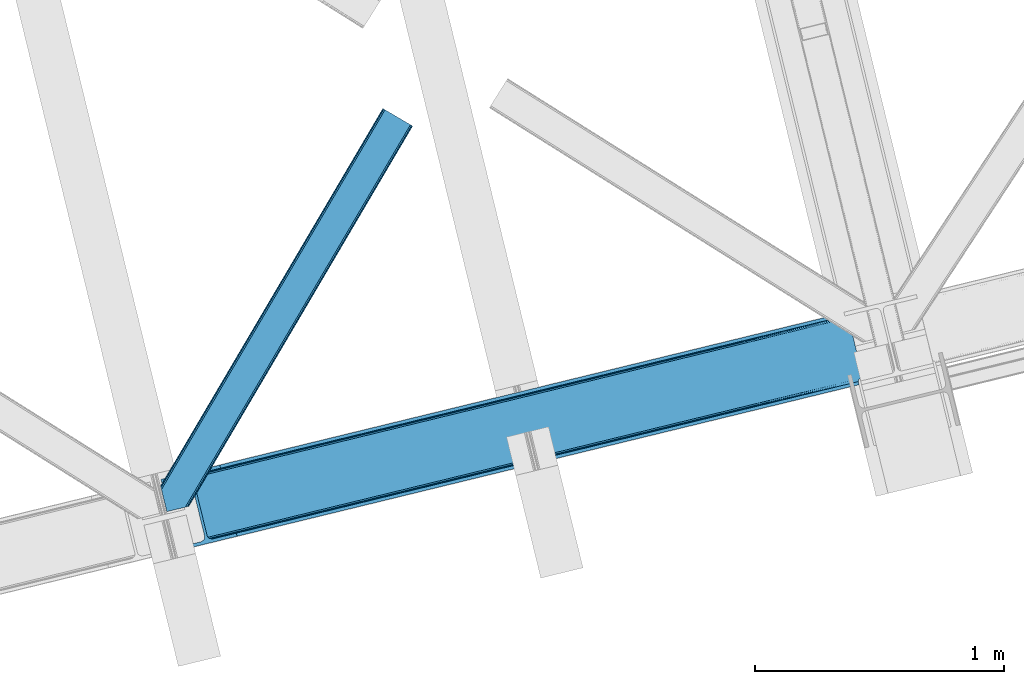
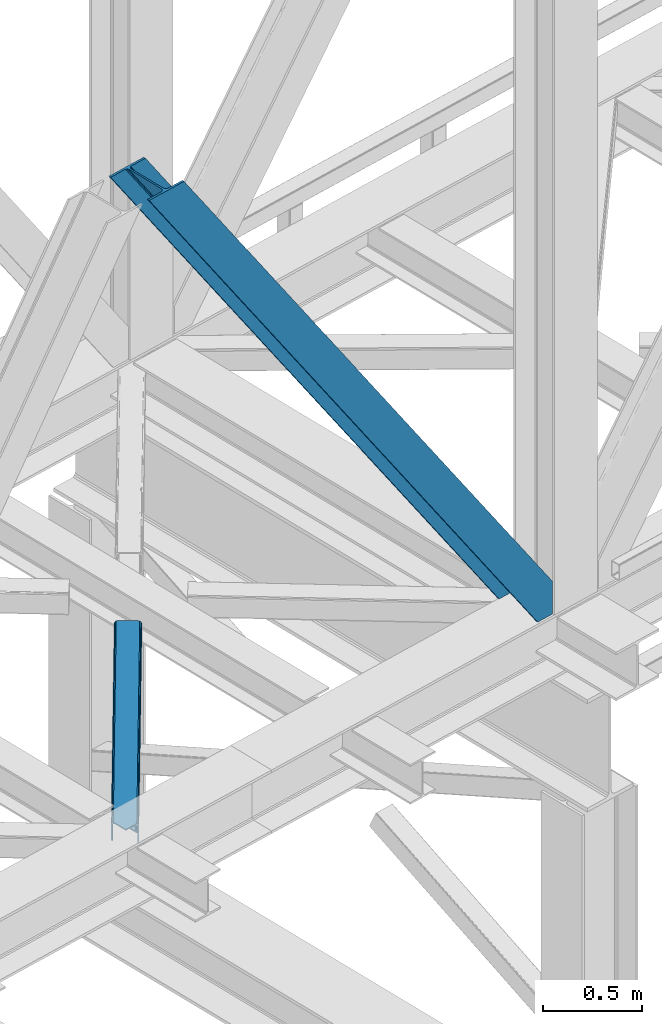
# One storey, part 34 of 93: 2 members.
"""IFC4 building model written with IfcOpenShell, lengths in millimetres."""

from ifc_helpers import new_model, entity, si_unit, converted_unit, derived_unit, direction, frame, origin, place, context, subcontext, project, spatial, triangles, type_object, element, save


model = new_model("IFC4")

# Units and contexts
model_context = context("Model", 3, precision=0.01, world=origin(), true_north=direction((6.12303176911189e-17, 1.0)))
plan_context = context("Plan", 3, precision=0.01, world=origin(), true_north=direction((6.12303176911189e-17, 1.0)))
body_context = subcontext(model_context, "Body", "Model", "MODEL_VIEW")
ifc_project = project(units=[si_unit("LENGTHUNIT", "METRE", prefix="MILLI"), si_unit("AREAUNIT", "SQUARE_METRE"), si_unit("VOLUMEUNIT", "CUBIC_METRE"), converted_unit("PLANEANGLEUNIT", "DEGREE", entity("IfcRatioMeasure", 0.0174532925199433), si_unit("PLANEANGLEUNIT", "RADIAN"), dimensions=[0, 0, 0, 0, 0, 0, 0]), si_unit("MASSUNIT", "GRAM", prefix="KILO"), derived_unit("MASSDENSITYUNIT", [(si_unit("MASSUNIT", "GRAM", prefix="KILO"), 1), (si_unit("LENGTHUNIT", "METRE"), -3)]), derived_unit("MOMENTOFINERTIAUNIT", [(si_unit("LENGTHUNIT", "METRE"), 4)]), si_unit("TIMEUNIT", "SECOND"), si_unit("FREQUENCYUNIT", "HERTZ"), si_unit("THERMODYNAMICTEMPERATUREUNIT", "DEGREE_CELSIUS"), derived_unit("THERMALTRANSMITTANCEUNIT", [(si_unit("MASSUNIT", "GRAM", prefix="KILO"), 1), (si_unit("THERMODYNAMICTEMPERATUREUNIT", "KELVIN"), -1), (si_unit("TIMEUNIT", "SECOND"), -3)]), derived_unit("VOLUMETRICFLOWRATEUNIT", [(si_unit("LENGTHUNIT", "METRE"), 3), (si_unit("TIMEUNIT", "SECOND"), -1)]), derived_unit("MASSFLOWRATEUNIT", [(si_unit("MASSUNIT", "GRAM", prefix="KILO"), 1), (si_unit("TIMEUNIT", "SECOND"), -1)]), derived_unit("ROTATIONALFREQUENCYUNIT", [(si_unit("TIMEUNIT", "SECOND"), -1)]), si_unit("ELECTRICCURRENTUNIT", "AMPERE"), si_unit("ELECTRICVOLTAGEUNIT", "VOLT"), si_unit("POWERUNIT", "WATT"), si_unit("FORCEUNIT", "NEWTON", prefix="KILO"), si_unit("ILLUMINANCEUNIT", "LUX"), si_unit("LUMINOUSFLUXUNIT", "LUMEN"), si_unit("LUMINOUSINTENSITYUNIT", "CANDELA"), derived_unit("USERDEFINED", [(si_unit("MASSUNIT", "GRAM", prefix="KILO"), -1), (si_unit("LENGTHUNIT", "METRE"), -2), (si_unit("TIMEUNIT", "SECOND"), 3), (si_unit("LUMINOUSFLUXUNIT", "LUMEN"), 1)]), derived_unit("LINEARVELOCITYUNIT", [(si_unit("LENGTHUNIT", "METRE"), 1), (si_unit("TIMEUNIT", "SECOND"), -1)]), si_unit("PRESSUREUNIT", "PASCAL"), derived_unit("USERDEFINED", [(si_unit("LENGTHUNIT", "METRE"), -2), (si_unit("MASSUNIT", "GRAM", prefix="KILO"), 1), (si_unit("TIMEUNIT", "SECOND"), -2)]), derived_unit("LINEARFORCEUNIT", [(si_unit("MASSUNIT", "GRAM", prefix="KILO"), 1), (si_unit("LENGTHUNIT", "METRE"), 1), (si_unit("TIMEUNIT", "SECOND"), -2), (si_unit("LENGTHUNIT", "METRE"), -1)]), derived_unit("PLANARFORCEUNIT", [(si_unit("MASSUNIT", "GRAM", prefix="KILO"), 1), (si_unit("LENGTHUNIT", "METRE"), 1), (si_unit("TIMEUNIT", "SECOND"), -2), (si_unit("LENGTHUNIT", "METRE"), -2)])], contexts=[model_context, plan_context])

# Site, building, storey
site_placement = place(None, origin())
site = spatial("IfcSite", under=ifc_project, at=site_placement, CompositionType="ELEMENT")
building_placement = place(site_placement, origin())
building = spatial("IfcBuilding", under=site, at=building_placement, CompositionType="ELEMENT")
storey_placement = place(building_placement, frame((0.0, 0.0, 15900.0)))
storey = spatial("IfcBuildingStorey", under=building, at=storey_placement, CompositionType="ELEMENT", Elevation=15900.0)

# Members
member_type_1 = type_object("IfcMemberType", PredefinedType="BRACE")
member_1_placement = place(storey_placement, frame((-51544.6723754883, 4902.22868041992, 3694.99929199219)))
element("IfcMember", 1, at=member_1_placement, inside=storey, type_object=member_type_1, ObjectType="Steel Vertical Brace", PredefinedType="BRACE", context=body_context, shape_type="Tessellation", body=[
    triangles([(2824.16715087891, 696.209248352051, 0.781347656247817), (2824.8368774414, 695.227331542968, 1.0697021484375), (2823.33929443359, 694.862237548828, 0.0), (2821.44173583984, 702.634437561035, 0.0), (2812.37717285156, 692.190307617188, 19.5569458007813), (2812.37717285156, 692.190307617188, 0.0), (2386.756640625, 583.573681640625, 658.75048828125), (2392.34234619141, 580.919773864746, 662.07819213867), (2803.98698730469, 681.261904907226, 51.2480346679658), (2804.11256103516, 683.186206054687, 44.4996093749978), (2382.25458984375, 588.487916564942, 656.525042724606), (2808.48438720703, 690.37995300293, 26.4030395507798), (2805.01483154297, 685.663961791992, 38.2720825195283), (2805.58223876953, 687.217936706543, 34.3676696777329), (630.515002441411, 150.045492553711, 3288.98063964843), (624.69210205078, 150.036772155761, 3285.05529785156), (211.331286621098, 47.8651016235353, 3911.00081176758), (202.862036132814, 47.2110717773439, 3911.00081176758), (619.106396484378, 152.691261291504, 3281.72759399414), (195.034606933594, 49.3185012817385, 3911.00081176758), (614.608996582036, 157.60549621582, 3279.50447387695), (189.034973144531, 53.8676422119142, 3911.00081176758), (611.88358154297, 164.031266784668, 3278.7231262207), (185.784008789065, 60.1649322509766, 3911.00081176758), (2804.10325927735, 679.880593872071, 63.6403015136711), (2398.16524658203, 580.928494262695, 666.003533935545), (1956.25268554688, 473.207743835449, 1321.74955444336), (1950.42978515625, 473.198442077637, 1317.82188720703), (1508.5172241211, 365.477691650391, 1973.56790771484), (1514.34012451172, 365.486993408203, 1977.49324951172), (1066.60466308594, 257.757522583008, 2629.3116027832), (1072.42756347657, 257.766242980957, 2633.23694458008), (1944.84407958984, 475.853512573242, 1314.49418334961), (1502.93151855469, 368.132180786133, 1970.23787841797), (1061.01895751953, 260.411430358887, 2625.98389892578), (1940.3466796875, 480.767166137695, 1312.27106323242), (1498.43411865235, 373.046997070313, 1968.01475830078), (1056.52155761719, 265.326246643066, 2623.75845336914), (2379.52917480469, 594.913687133789, 655.74602050781), (1937.62126464844, 487.192936706543, 1311.48971557617), (1495.70870361328, 379.47276763916, 1967.23341064453), (1053.79614257813, 271.751435852051, 2622.97710571289), (2766.2637084961, 929.006085205078, 0.0), (2324.35114746094, 821.285334777832, 655.74602050781), (1882.43858642579, 713.564584350586, 1311.48971557617), (1440.52602539062, 605.844415283203, 1967.23341064453), (998.613464355469, 498.123083496093, 2622.97710571289), (556.705554199223, 390.402914428711, 3278.7231262207), (130.605981445311, 286.53657989502, 3911.00081176758), (303.26520996094, 70.2741989135739, 3911.00081176758), (2804.10325927735, 679.880593872071, 200.055230712889), (2807.13563232422, 667.239505004883, 200.120343017577), (2804.2939453125, 678.898095703125, 200.120343017577), (306.344091796876, 57.6441558837887, 3911.00081176758), (2807.13563232422, 667.239505004883, 0.0), (2804.2939453125, 678.898095703125, 0.0), (2803.9962890625, 682.092668151856, 0.0), (2804.11256103516, 683.186206054687, 2.42078247070094), (2804.71717529297, 685.456416320801, 5.12991943359157), (2805.58223876953, 687.217936706543, 5.67639770507594), (2807.01470947266, 689.087008666992, 4.89505004882813), (2808.48438720703, 690.37995300293, 3.35328369140552), (2811.03771972656, 691.772309875489, 0.0), (2705.51857910156, 642.469505310059, 0.0), (69.8608520507842, 0.0, 3911.00081176758), (2794.37362060547, 677.508645629883, 0.0), (2801.99641113282, 681.139819335937, 0.0), (2702.43969726563, 655.099548339844, 0.0), (66.7819702148481, 12.6300430297852, 3911.00081176758), (1480.00268554688, 357.11657409668, 1950.37164916992), (1034.28570556641, 248.469136047363, 2611.75686035156), (588.573376464847, 139.821697998047, 3273.1420715332), (158.71589355469, 35.0391403198246, 3911.00081176758), (1925.71501464844, 465.764012145996, 1288.98643798828), (2371.42734375, 574.411450195313, 627.598901367186), (2376.60377197266, 577.083380126953, 631.526568603513), (2380.33842773438, 582.010404968261, 634.854272460936), (2381.53370361328, 595.402029418945, 637.858740234373), (2811.39118652344, 700.184587097168, 0.0), (2811.09353027344, 693.083276367188, 0.0), (2382.0732055664, 588.443151855468, 637.077392578125), (598.679736328129, 160.812277221679, 3283.40191040039), (599.21923828125, 153.853399658203, 3282.62056274414), (175.733459472656, 57.7150817871097, 3911.00081176758), (175.747412109376, 50.6277236938477, 3911.00081176758), (597.484460449217, 147.420652770996, 3280.39744262695), (172.515051269533, 43.8298828124998, 3911.00081176758), (593.749804687504, 142.493627929687, 3277.06973876953), (166.534020996092, 38.3557983398441, 3911.00081176758), (1935.82137451172, 486.754591369629, 1299.24395141601), (1936.36087646485, 479.795713806152, 1298.46260375976), (1490.10904541016, 378.107153320312, 1960.63148803711), (1490.64389648438, 371.148275756836, 1959.85014038086), (1044.93156738282, 262.500837707519, 2621.2353515625), (1044.39206542969, 269.459715270996, 2622.01669921875), (1934.62609863281, 473.362966918945, 1296.23948364258), (1488.91376953125, 364.715528869629, 1957.62469482422), (1043.20144042969, 256.068090820312, 2619.01223144531), (1930.88679199219, 468.435360717774, 1292.91177978515), (1485.17446289062, 359.78850402832, 1954.2969909668), (1039.46213378906, 251.141065979004, 2615.68220214844), (2756.21315917969, 926.556234741211, 0.0), (2326.35567626953, 821.773677062988, 637.858740234373), (1434.9263671875, 604.478800964355, 1960.63148803711), (1880.63869628906, 713.126239013672, 1299.24395141601), (989.214038085942, 495.831362915039, 2622.01669921875), (543.501708984375, 387.183924865722, 3283.40191040039), (120.555432128909, 284.086729431152, 3911.00081176758), (2752.67849121094, 932.723300170898, 0.0), (2753.40867919922, 934.106936645508, 0.0), (2752.02736816406, 933.862184143067, 0.0), (2764.36614990234, 936.778285217285, 0.0), (2753.40867919922, 934.106936645508, 19.5569458007813), (2765.86373291015, 937.143960571289, 1.0697021484375), (2765.72420654297, 935.965544128418, 0.781347656247817), (2325.54642333985, 834.677540588379, 658.75048828125), (2749.12056884765, 933.923226928711, 26.4030395507798), (2745.08825683594, 935.394648742676, 34.3676696777329), (2323.81164550781, 828.244212341308, 656.525042724606), (2743.50695800781, 936.560275268555, 38.5441589355469), (556.166052246095, 397.361791992187, 3279.50447387695), (130.592028808598, 293.623937988281, 3911.00081176758), (557.896179199219, 403.794538879394, 3281.72759399414), (133.824389648442, 300.422360229492, 3911.00081176758), (561.635485839848, 408.721563720703, 3285.05529785156), (139.805419921875, 305.895863342285, 3911.00081176758), (566.807263183597, 411.393493652344, 3288.98063964843), (147.623547363284, 309.212521362305, 3911.00081176758), (2740.92572021484, 939.947277832031, 51.2480346679658), (2740.39552001953, 941.22801361084, 63.6403015136711), (2329.28572998047, 839.604565429688, 662.07819213867), (2334.45750732422, 842.275914001465, 666.003533935545), (2742.08843994141, 938.421208190918, 45.5251281738274), (1881.89908447266, 720.523461914063, 1312.27106323242), (1439.9911743164, 612.80329284668, 1968.01475830078), (998.07861328125, 505.082542419434, 2623.75845336914), (1883.63386230469, 726.956790161133, 1314.49418334961), (1441.72130126954, 619.235458374023, 1970.23787841797), (999.808740234374, 511.515289306641, 2625.98389892578), (1887.36851806641, 731.883815002441, 1317.82188720703), (1445.46060791016, 624.163064575196, 1973.56790771484), (1003.548046875, 516.442314147949, 2629.3116027832), (1892.54494628906, 734.555163574219, 1321.74955444336), (1450.63238525391, 626.834413146973, 1977.49324951172), (1008.71982421875, 519.11424407959, 2633.23694458008), (2740.39552001953, 941.22801361084, 200.055230712889), (239.557470703126, 331.622200012207, 3911.00081176758), (2749.12056884765, 933.923226928711, 3.35328369140552), (2745.08825683594, 935.394648742676, 5.67639770507594), (2747.22301025391, 934.392384338379, 4.89272460937354), (2743.50695800781, 936.560275268555, 5.12991943359157), (2740.11646728516, 942.189001464843, 0.0), (2741.92565917969, 938.297378540039, 2.42078247070094), (2740.11646728516, 942.189001464843, 200.120343017577), (2741.32104492188, 939.215927124023, 0.0), (2323.63026123047, 828.199447631836, 637.077392578125), (2319.13286132813, 833.113682556153, 634.854272460936), (2313.54715576172, 835.768171691894, 631.526568603513), (2307.71960449219, 835.758869934082, 627.598901367186), (2730.66588134766, 938.856065368653, 0.0), (2739.1072265625, 939.140931701661, 0.0), (524.865637207033, 401.169117736817, 3273.1420715332), (530.688537597656, 401.178419494629, 3277.06973876953), (103.477404785161, 297.041171264648, 3911.00081176758), (95.0081542968765, 296.386560058594, 3911.00081176758), (536.274243164065, 398.523930358887, 3280.39744262695), (111.304833984374, 294.933160400391, 3911.00081176758), (540.776293945317, 393.60969543457, 3282.62056274414), (117.304467773436, 290.384019470215, 3911.00081176758), (1867.83017578125, 727.120733642578, 1292.91177978515), (1862.00727539063, 727.111431884766, 1288.98643798828), (1422.11784667969, 618.473295593261, 1954.2969909668), (1416.29494628906, 618.463993835449, 1950.37164916992), (976.405517578125, 509.825857543945, 2615.68220214844), (970.582617187501, 509.816555786133, 2611.75686035156), (1873.41588134766, 724.466244506836, 1296.23948364258), (1427.70355224609, 615.81880645752, 1957.62469482422), (981.991223144534, 507.171368408203, 2619.01223144531), (1877.9179321289, 719.55200958252, 1298.46260375976), (1432.20095214844, 610.904571533203, 1959.85014038086), (986.488623046876, 502.257133483887, 2621.2353515625), (2737.27478027344, 953.847592163086, 200.120343017577), (236.47858886719, 344.252243041992, 3911.00081176758), (2737.27478027344, 953.847592163086, 0.0), (0.0, 286.60750579834, 3911.00081176758), (3.07888183593604, 273.977462768555, 3911.00081176758), (2635.65772705078, 929.077011108398, 0.0), (2638.73660888672, 916.446968078613, 0.0)], [[1, 2, 3], [3, 4, 1], [2, 5, 6], [6, 3, 2], [7, 8, 9], [9, 10, 7], [11, 12, 5], [5, 1, 11], [5, 2, 1], [11, 7, 13], [13, 14, 11], [14, 12, 11], [15, 16, 17], [18, 17, 16], [16, 19, 18], [20, 18, 19], [19, 21, 20], [22, 20, 21], [21, 23, 22], [24, 22, 23], [10, 13, 7], [25, 9, 8], [8, 26, 25], [26, 8, 27], [28, 27, 8], [27, 28, 29], [29, 30, 27], [30, 29, 31], [31, 32, 30], [32, 31, 15], [16, 15, 31], [8, 7, 33], [33, 28, 8], [28, 33, 29], [34, 29, 33], [29, 34, 31], [35, 31, 34], [31, 35, 19], [19, 16, 31], [7, 11, 36], [36, 33, 7], [33, 36, 37], [37, 34, 33], [34, 37, 35], [38, 35, 37], [35, 38, 19], [21, 19, 38], [1, 4, 39], [39, 11, 1], [11, 39, 36], [40, 36, 39], [36, 40, 37], [41, 37, 40], [37, 41, 42], [42, 38, 37], [38, 42, 21], [23, 21, 42], [4, 43, 44], [45, 39, 44], [41, 40, 45], [41, 45, 46], [44, 39, 4], [45, 40, 39], [42, 41, 46], [46, 47, 42], [47, 48, 23], [49, 24, 48], [47, 23, 42], [48, 24, 23], [50, 51, 30], [30, 32, 50], [32, 15, 50], [17, 50, 15], [27, 30, 51], [51, 25, 26], [26, 27, 51], [52, 53, 54], [53, 51, 50], [50, 54, 53], [52, 55, 53], [56, 53, 55], [56, 9, 25], [56, 57, 58], [58, 10, 56], [10, 9, 56], [59, 60, 14], [14, 13, 59], [10, 58, 59], [60, 61, 12], [12, 14, 60], [5, 62, 63], [63, 6, 5], [5, 12, 62], [61, 62, 12], [13, 10, 59], [25, 51, 53], [53, 56, 25], [54, 64, 52], [54, 65, 64], [64, 55, 52], [56, 66, 67], [55, 66, 56], [67, 57, 56], [64, 66, 55], [64, 68, 66], [68, 64, 65], [65, 69, 68], [69, 70, 68], [71, 69, 72], [69, 71, 70], [69, 73, 72], [74, 68, 70], [66, 68, 75], [74, 75, 68], [67, 76, 58], [76, 77, 59], [59, 58, 76], [76, 67, 66], [78, 79, 80], [81, 60, 59], [81, 80, 62], [62, 61, 81], [61, 60, 81], [80, 63, 62], [59, 77, 81], [80, 81, 78], [82, 83, 84], [85, 84, 83], [83, 86, 85], [87, 85, 86], [86, 88, 87], [89, 87, 88], [88, 72, 89], [73, 89, 72], [66, 75, 76], [58, 57, 67], [78, 81, 90], [91, 90, 81], [90, 91, 92], [93, 92, 91], [92, 93, 94], [94, 95, 92], [95, 94, 83], [83, 82, 95], [81, 77, 96], [96, 91, 81], [91, 96, 93], [97, 93, 96], [93, 97, 98], [98, 94, 93], [94, 98, 83], [86, 83, 98], [77, 76, 99], [99, 96, 77], [96, 99, 100], [100, 97, 96], [97, 100, 101], [101, 98, 97], [98, 101, 88], [88, 86, 98], [76, 75, 99], [74, 99, 75], [99, 74, 100], [70, 100, 74], [100, 70, 101], [71, 101, 70], [101, 71, 88], [72, 88, 71], [102, 79, 78], [90, 103, 78], [104, 105, 90], [104, 90, 92], [78, 103, 102], [90, 105, 103], [106, 104, 92], [92, 95, 106], [95, 82, 107], [84, 108, 82], [95, 107, 106], [82, 108, 107], [109, 102, 110], [6, 79, 80], [6, 80, 63], [110, 111, 109], [3, 79, 6], [79, 4, 102], [3, 4, 79], [43, 102, 4], [102, 112, 110], [112, 102, 43], [113, 114, 110], [112, 110, 114], [114, 115, 112], [43, 112, 115], [116, 117, 118], [119, 115, 113], [113, 116, 119], [113, 117, 116], [115, 114, 113], [118, 120, 116], [48, 121, 122], [122, 49, 48], [121, 123, 124], [124, 122, 121], [123, 125, 126], [126, 124, 123], [125, 127, 128], [128, 126, 125], [129, 130, 131], [132, 131, 130], [133, 116, 120], [116, 133, 129], [131, 116, 129], [43, 115, 119], [119, 44, 43], [44, 119, 134], [134, 45, 44], [45, 134, 135], [135, 46, 45], [46, 135, 47], [136, 47, 135], [47, 136, 121], [121, 48, 47], [119, 116, 134], [137, 134, 116], [134, 137, 135], [138, 135, 137], [135, 138, 139], [139, 136, 135], [136, 139, 123], [123, 121, 136], [116, 131, 137], [140, 137, 131], [137, 140, 141], [141, 138, 137], [138, 141, 142], [142, 139, 138], [139, 142, 123], [125, 123, 142], [131, 132, 143], [143, 140, 131], [140, 143, 141], [144, 141, 143], [141, 144, 142], [145, 142, 144], [142, 145, 127], [127, 125, 142], [144, 146, 147], [147, 127, 145], [127, 147, 128], [145, 144, 147], [146, 144, 143], [143, 132, 146], [130, 146, 132], [113, 110, 111], [148, 117, 113], [149, 118, 117], [117, 148, 150], [151, 133, 120], [118, 149, 151], [151, 120, 118], [152, 133, 153], [152, 129, 133], [146, 130, 154], [152, 154, 130], [130, 129, 152], [153, 155, 152], [151, 153, 133], [117, 150, 149], [111, 148, 113], [156, 150, 148], [156, 149, 150], [148, 109, 156], [148, 111, 109], [156, 157, 151], [151, 149, 156], [103, 156, 109], [158, 159, 160], [158, 153, 151], [158, 161, 153], [161, 155, 153], [151, 157, 158], [160, 161, 158], [162, 163, 164], [164, 165, 162], [163, 166, 167], [167, 164, 163], [166, 168, 169], [169, 167, 166], [168, 107, 108], [108, 169, 168], [109, 102, 103], [159, 158, 170], [170, 171, 159], [171, 170, 172], [172, 173, 171], [173, 172, 174], [174, 175, 173], [175, 174, 163], [163, 162, 175], [158, 157, 170], [176, 170, 157], [170, 176, 172], [177, 172, 176], [172, 177, 174], [178, 174, 177], [174, 178, 163], [166, 163, 178], [157, 156, 176], [179, 176, 156], [176, 179, 180], [180, 177, 176], [177, 180, 178], [181, 178, 180], [178, 181, 168], [168, 166, 178], [156, 103, 105], [105, 179, 156], [179, 105, 104], [104, 180, 179], [180, 104, 106], [106, 181, 180], [181, 106, 168], [107, 168, 106], [146, 154, 147], [154, 182, 183], [183, 147, 154], [154, 152, 184], [184, 182, 154], [108, 84, 49], [87, 89, 18], [73, 65, 54], [69, 65, 73], [89, 73, 17], [84, 85, 22], [85, 87, 20], [167, 126, 164], [185, 165, 183], [165, 164, 128], [185, 186, 165], [167, 169, 124], [169, 108, 122], [49, 84, 24], [17, 18, 89], [22, 85, 20], [18, 20, 87], [22, 24, 84], [54, 17, 73], [54, 50, 17], [128, 164, 126], [124, 169, 122], [49, 122, 108], [124, 126, 167], [128, 183, 165], [183, 128, 147], [152, 160, 184], [155, 161, 152], [152, 161, 160], [160, 187, 184], [187, 160, 188], [183, 187, 185], [187, 183, 182], [184, 187, 182], [173, 186, 188], [162, 186, 175], [162, 165, 186], [173, 175, 186], [188, 171, 173], [159, 171, 188], [188, 160, 159], [187, 188, 185], [186, 185, 188]]),
])
member_type_2 = type_object("IfcMemberType", PredefinedType="BRACE")
member_2_placement = place(storey_placement, frame((-51546.0815917969, 5059.05399169922, 3511.0000579834)))
element("IfcMember", 2, at=member_2_placement, inside=storey, type_object=member_type_2, ObjectType="Steel Horizontal Brace", PredefinedType="BRACE", context=body_context, shape_type="Tessellation", body=[
    triangles([(154.446386718751, 124.70924835205, 0.0), (118.769494628912, 271.071826171875, 0.0), (998.971582031256, 1559.19901428223, 0.0), (908.484082031253, 1612.46901855469, 0.0), (1004.73867187501, 1555.80154724121, 1.33247680664135), (156.720666503912, 115.37377166748, 1.33247680664135), (1009.63604736328, 1552.92090911865, 5.12526855468968), (158.650781250006, 107.459719848633, 5.12526855468968), (1012.90096435547, 1550.99602661133, 10.8028289794929), (159.939074707036, 102.17225189209, 10.8028289794929), (1014.04973144532, 1550.32048645019, 17.5000946044929), (160.39020996094, 100.315388488769, 17.5000946044929), (902.716992187503, 1615.8664855957, 1.33247680664135), (116.495214843751, 280.406721496582, 1.33247680664135), (114.574401855469, 288.276008605957, 5.17061462402489), (897.824267578129, 1618.74712371826, 5.12526855468968), (114.495336914064, 288.596919250488, 5.32641906738354), (894.554699707034, 1620.67142486572, 10.8028289794929), (109.625866699222, 287.409201049804, 10.8028289794929), (893.405932617192, 1621.34754638672, 17.5000946044929), (107.821325683595, 286.969692993163, 17.5000946044929), (113.523303222661, 288.360305786133, 18.5197998046897), (114.495336914064, 288.596919250488, 17.5198608398459), (114.420922851568, 288.578897094726, 17.9023956298843), (114.211633300787, 288.527737426757, 18.2279571533218), (113.895373535161, 288.450416564941, 18.4442230224631), (107.821325683595, 286.969692993163, 18.5197998046897), (115.695263671878, 283.683847045898, 17.5198608398459), (115.625500488284, 283.800700378418, 17.8035644531265), (115.565039062501, 283.7408203125, 17.8570495605491), (115.318542480469, 283.496067810058, 18.0768035888686), (115.067395019534, 283.239688110351, 18.3081848144539), (114.830200195313, 283.003656005859, 18.5197998046897), (0.0, 103.825057983398, 18.5197998046897), (2.73471679687646, 92.5989990234375, 18.5197998046897), (893.405932617192, 1621.34754638672, 122.500662231447), (0.0, 103.825057983398, 122.500662231447), (908.484082031253, 1612.46901855469, 139.999594116212), (902.716992187503, 1615.8664855957, 138.667117309571), (3.66954345703562, 88.766093444824, 138.667117309571), (5.94382324218896, 79.4311981201172, 139.999594116212), (897.824267578129, 1618.74712371826, 134.874325561526), (1.73942871094187, 96.6801452636719, 134.874325561526), (894.554699707034, 1620.67142486572, 129.197927856447), (0.451135253912071, 101.968194580078, 129.197927856447), (899.438122558597, 1617.79601898193, 24.4996673583992), (2.37659912109666, 94.0675140380854, 24.4996673583992), (900.586889648439, 1617.1204788208, 17.8035644531265), (903.856457519534, 1615.19559631348, 12.1260040283232), (914.516271972658, 1608.9174911499, 6.99957275390625), (908.749182128908, 1612.31553955078, 8.3320495605476), (118.871813964848, 270.64917755127, 8.3320495605476), (121.146093750001, 261.314282226562, 6.99957275390625), (116.941699218754, 278.563229370116, 12.1260040283232), (152.069787597662, 134.466792297363, 6.99957275390625), (992.939392089844, 1562.75054168701, 6.99957275390625), (156.274182128909, 117.217263793945, 12.1260040283232), (154.344067382815, 125.131315612793, 8.3320495605476), (157.520617675786, 112.097227478027, 17.5198608398459), (160.39020996094, 100.315388488769, 17.5198608398459), (899.438122558597, 1617.79601898193, 115.501089477541), (2.37659912109666, 94.0675140380854, 115.501089477541), (900.586889648439, 1617.1204788208, 122.196029663086), (2.82773437500146, 92.2106506347654, 122.196029663086), (903.856457519534, 1615.19559631348, 127.87475280762), (4.12067871094041, 86.9226013183588, 127.87475280762), (908.749182128908, 1612.31553955078, 131.667544555665), (6.046142578125, 79.008549499511, 131.667544555665), (914.516271972658, 1608.9174911499, 133.000021362306), (8.3250732421875, 69.6736541748041, 133.000021362306), (25.3054321289092, 0.0, 133.000021362306), (25.3054321289092, 0.0, 139.999594116212), (90.3619262695356, 15.8583343505852, 139.999594116212), (998.971582031256, 1559.19901428223, 139.999594116212), (1014.04973144532, 1550.32048645019, 122.500662231447), (1012.90096435547, 1550.99602661133, 129.197927856447), (114.0721069336, 21.6382141113281, 122.500662231447), (112.267565917973, 21.1981246948235, 129.197927856447), (1009.63604736328, 1552.92090911865, 134.874325561526), (107.128344726567, 19.9452941894524, 134.874325561526), (1004.73867187501, 1555.80154724121, 138.667117309571), (99.435791015625, 18.0698272705076, 138.667117309571), (159.664672851563, 99.0788360595698, 18.5197998046897), (114.0721069336, 21.6382141113281, 18.5197998046897), (103.161145019534, 18.9784927368164, 18.5197998046897), (156.929956054693, 110.304895019531, 18.5197998046897), (1008.01754150391, 1553.87201385498, 24.4996673583992), (1006.86877441406, 1554.54755401611, 17.8035644531265), (157.222961425781, 111.200770568847, 18.0198303222678), (1003.60385742188, 1556.47243652344, 12.1260040283232), (998.706481933594, 1559.35249328613, 8.3320495605476), (104.588964843751, 19.3261459350579, 24.4996673583992), (1003.60385742188, 1556.47243652344, 127.87475280762), (1008.01754150391, 1553.87201385498, 115.501089477541), (1006.86877441406, 1554.54755401611, 122.196029663086), (992.939392089844, 1562.75054168701, 133.000021362306), (998.706481933594, 1559.35249328613, 131.667544555665), (102.784423828125, 18.8860565185541, 122.196029663086), (80.8787841796875, 13.5468475341795, 133.000021362306), (89.9526489257842, 15.758340454101, 131.667544555665), (97.6452026367188, 17.633226013183, 127.87475280762), (104.588964843751, 19.3261459350579, 115.501089477541)], [[1, 2, 3], [4, 3, 2], [3, 5, 1], [6, 1, 5], [5, 7, 6], [8, 6, 7], [7, 9, 8], [10, 8, 9], [9, 11, 10], [12, 10, 11], [13, 14, 15], [16, 15, 17], [17, 18, 16], [17, 19, 18], [20, 18, 19], [19, 21, 20], [15, 16, 13], [13, 4, 14], [2, 14, 4], [22, 23, 24], [22, 25, 26], [27, 21, 22], [24, 25, 22], [23, 22, 21], [21, 19, 23], [17, 23, 19], [23, 28, 29], [29, 24, 23], [25, 24, 30], [26, 25, 31], [22, 26, 32], [32, 33, 22], [31, 32, 26], [30, 31, 25], [29, 30, 24], [34, 33, 35], [33, 34, 27], [22, 33, 27], [27, 20, 21], [36, 27, 37], [27, 36, 20], [27, 34, 37], [38, 39, 40], [40, 41, 38], [39, 42, 43], [43, 40, 39], [42, 44, 45], [45, 43, 42], [44, 36, 37], [37, 45, 44], [46, 47, 33], [33, 48, 46], [33, 31, 48], [47, 35, 33], [49, 48, 28], [50, 51, 52], [52, 53, 50], [51, 49, 54], [54, 52, 51], [28, 54, 49], [53, 55, 56], [56, 50, 53], [55, 2, 1], [54, 17, 14], [52, 14, 2], [52, 2, 53], [55, 53, 2], [17, 28, 23], [54, 28, 17], [52, 54, 14], [57, 58, 6], [58, 1, 6], [1, 58, 55], [8, 57, 6], [8, 59, 57], [10, 59, 8], [10, 60, 59], [46, 61, 47], [62, 47, 61], [61, 63, 62], [64, 62, 63], [63, 65, 64], [66, 64, 65], [65, 67, 66], [68, 66, 67], [67, 69, 68], [70, 68, 69], [66, 43, 64], [71, 72, 70], [72, 41, 70], [40, 68, 41], [66, 68, 40], [68, 70, 41], [66, 40, 43], [37, 34, 62], [45, 64, 43], [62, 64, 37], [64, 45, 37], [34, 47, 62], [34, 35, 47], [41, 73, 74], [73, 41, 72], [74, 38, 41], [75, 76, 77], [78, 77, 76], [76, 79, 78], [80, 78, 79], [79, 81, 80], [82, 80, 81], [81, 74, 82], [73, 82, 74], [60, 75, 77], [60, 11, 75], [77, 83, 60], [77, 84, 83], [84, 85, 83], [86, 83, 85], [87, 88, 59], [89, 86, 87], [88, 90, 57], [57, 59, 88], [90, 91, 58], [58, 57, 90], [91, 56, 55], [55, 58, 91], [87, 86, 92], [85, 92, 86], [9, 90, 88], [87, 75, 11], [9, 88, 11], [9, 7, 90], [88, 87, 11], [90, 7, 5], [56, 3, 4], [3, 91, 5], [91, 3, 56], [91, 90, 5], [76, 93, 79], [94, 75, 87], [75, 95, 76], [95, 75, 94], [76, 95, 93], [74, 96, 38], [81, 79, 93], [93, 97, 81], [97, 96, 74], [74, 81, 97], [49, 13, 16], [4, 50, 56], [4, 51, 50], [51, 4, 13], [49, 51, 13], [46, 20, 36], [18, 48, 49], [16, 18, 49], [48, 18, 20], [46, 48, 20], [39, 65, 42], [38, 96, 69], [69, 67, 38], [67, 65, 39], [39, 38, 67], [44, 42, 65], [36, 61, 46], [63, 36, 44], [36, 63, 61], [63, 44, 65], [98, 78, 80], [99, 73, 72], [72, 71, 99], [99, 100, 73], [100, 82, 73], [101, 82, 100], [80, 82, 101], [98, 77, 78], [102, 77, 98], [80, 101, 98], [84, 92, 85], [102, 84, 77], [92, 84, 102], [99, 70, 96], [99, 71, 70], [69, 96, 70], [96, 97, 100], [100, 99, 96], [97, 93, 101], [101, 100, 97], [93, 95, 98], [98, 101, 93], [95, 94, 102], [102, 98, 95], [94, 87, 92], [92, 102, 94]]),
])

save(model, "model.ifc")
